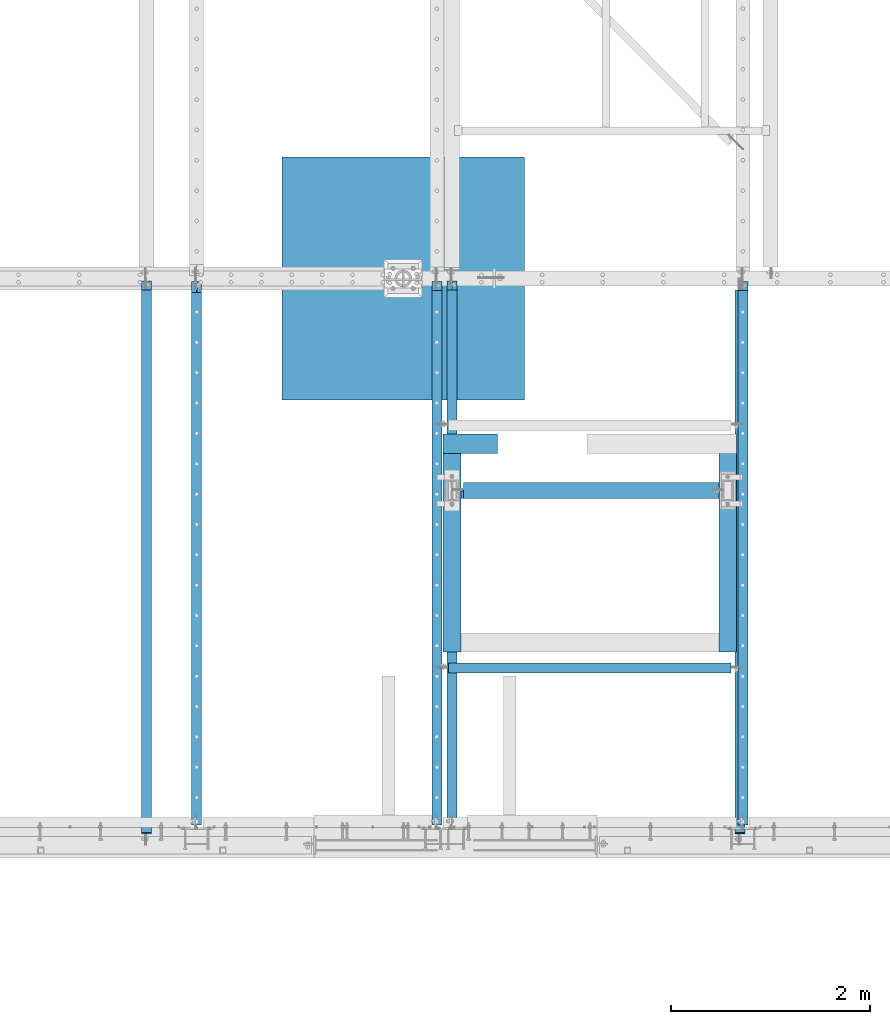
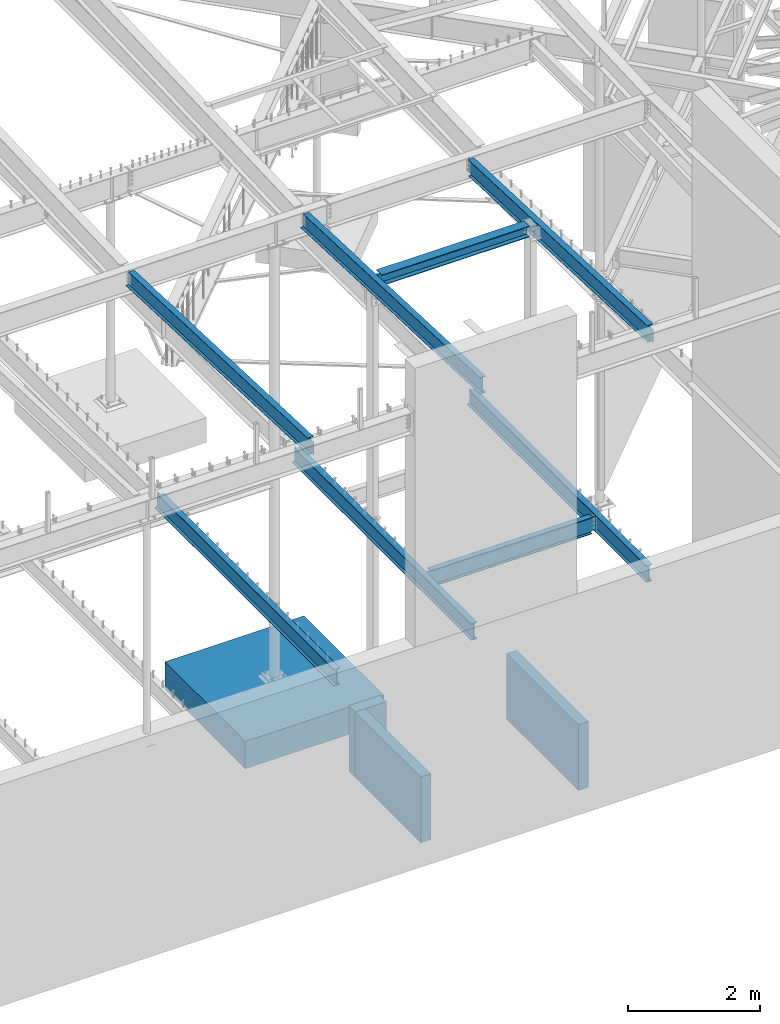
# One storey, part 315 of 975: 12 beams.
"""IFC2X3 building model written with IfcOpenShell, lengths in millimetres."""

from ifc_helpers import new_model, si_unit, frame, origin_with_axes, place, context, subcontext, project, spatial, faceted_brep, material, type_object, element, save


model = new_model("IFC2X3")

# Units and contexts
model_context = context("Model", 3, precision=1e-05, world=origin_with_axes())
body_context = subcontext(model_context, "Body", "Model", "MODEL_VIEW")
ifc_project = project(units=[si_unit("LENGTHUNIT", "METRE", prefix="MILLI"), si_unit("AREAUNIT", "SQUARE_METRE"), si_unit("VOLUMEUNIT", "CUBIC_METRE"), si_unit("MASSUNIT", "GRAM", prefix="KILO"), si_unit("TIMEUNIT", "SECOND"), si_unit("PLANEANGLEUNIT", "RADIAN"), si_unit("SOLIDANGLEUNIT", "STERADIAN"), si_unit("THERMODYNAMICTEMPERATUREUNIT", "DEGREE_CELSIUS"), si_unit("LUMINOUSINTENSITYUNIT", "LUMEN")], contexts=[model_context])

# Site, building, storey
site_placement = place(None, origin_with_axes())
site = spatial("IfcSite", under=ifc_project, at=site_placement, CompositionType="ELEMENT")
building_placement = place(site_placement, origin_with_axes())
building = spatial("IfcBuilding", under=site, at=building_placement, Name="Undefined", CompositionType="ELEMENT")
storey_placement = place(building_placement, origin_with_axes())
storey = spatial("IfcBuildingStorey", under=building, at=storey_placement, Name="Undefined", CompositionType="ELEMENT", Elevation=0.0)

# Beams
ifc_material_1 = material(Name="CONCRETE/5000")
beam_type_1 = type_object("IfcBeamType", PredefinedType="NOTDEFINED")
beam_1_placement = place(storey_placement, frame((23634.7000300942, 4160.83746255972, -609.6), z_axis=(0.0, 0.0, 1.0), x_axis=(1.0, 0.0, 0.0)))
element("IfcBeam", 1, at=beam_1_placement, inside=storey, type_object=beam_type_1, material=ifc_material_1, Name="WALL", context=body_context, shape_type="Brep", body=[
    faceted_brep([(0.0, 96.8375000000001, -609.6), (0.0, 96.8375000000001, 609.6), (546.100067562045, 96.8374999999996, 609.6), (546.100067562045, 96.8374999999996, -609.6), (0.0, -96.8375000000001, 609.6), (546.100067562045, -96.8375000000001, 609.6), (0.0, -96.8375000000001, -609.6), (546.100067562045, -96.8375000000001, -609.6)], [[[0, 1, 2, 3]], [[1, 4, 5, 2]], [[4, 6, 7, 5]], [[6, 0, 3, 7]], [[5, 7, 3, 2]], [[6, 4, 1, 0]]]),
])
beam_type_2 = type_object("IfcBeamType", PredefinedType="NOTDEFINED")
for number, where, z_axis, x_axis, name in (
    (2, (23723.6000300942, 2066.92513015896, -609.6), (0.0, 0.0, 1.0), (0.0, 1.0, 0.0), "WALL"),
    (3, (26492.2, 2066.92501138784, -609.6), (0.0, 0.0, 1.0), (0.0, 1.0, 0.0), "WALL"),
):
    element("IfcBeam", number, at=place(storey_placement, frame(where, z_axis=z_axis, x_axis=x_axis)), inside=storey, type_object=beam_type_2, material=ifc_material_1, Name=name, context=body_context, shape_type="Brep", body=[
        faceted_brep([(0.0, 88.9000000000015, -609.6), (0.0, 88.9000000000015, 609.6), (2190.74995117187, 88.9000000000015, 609.6), (2190.74995117187, 88.9000000000015, -609.6), (0.0, -88.9000000000015, 609.6), (2190.74995117187, -88.9000000000015, 609.6), (0.0, -88.9000000000015, -609.6), (2190.74995117187, -88.9000000000015, -609.6)], [[[0, 1, 2, 3]], [[1, 4, 5, 2]], [[4, 6, 7, 5]], [[6, 0, 3, 7]], [[5, 7, 3, 2]], [[6, 4, 1, 0]]]),
    ])
ifc_material_2 = material(Name="STEEL/A992")
beam_type_3 = type_object("IfcBeamType", Name="W12X14", PredefinedType="NOTDEFINED")
beam_2_placement = place(storey_placement, frame((26616.025, 95.5756617602171, 8307.50787178829), z_axis=(0.0, 0.039945880990807, 0.999201844770049), x_axis=(0.0, 0.999201844770049, -0.039945880990807)))
element("IfcBeam", 4, at=beam_2_placement, inside=storey, type_object=beam_type_3, material=ifc_material_2, Name="BEAM", ObjectType="W12X14", context=body_context, shape_type="Brep", body=[
    faceted_brep([(5608.57503248374, -2.38124999999854, -144.462500004352), (5608.57503248374, -50.7999999999993, -144.462500004352), (5608.57503248374, -50.7999999999993, -150.812500004353), (5608.57503248374, 50.7999999999993, -150.812500004353), (5608.57503248374, 50.7999999999993, -144.462500004352), (5608.57503248374, 2.38124999999854, -144.462500004352), (5608.57503248374, 2.38124999999854, -138.112499832895), (5608.57503248374, -2.38124999999854, -138.112499832895), (5609.54176240632, 2.38124999999854, -133.25242031485), (5609.54176240632, -2.38124999999854, -133.25242031485), (5612.2947763068, 2.38124999999854, -129.132243846697), (5612.2947763068, -2.38124999999854, -129.132243846697), (5616.41495277495, 2.38124999999854, -126.379229946219), (5616.41495277495, -2.38124999999854, -126.379229946219), (5621.27503229299, 2.38124999999854, -125.412500023635), (5621.27503229299, -2.38124999999854, -125.412500023635), (5709.15959663136, -2.38124999999854, -125.412500023731), (5709.15959663136, 2.38124999999854, -125.412500023731), (151.646194694746, 2.38124999999854, 144.462499999898), (151.646194694746, 50.7999999999993, 144.462499999898), (5608.57503248423, 50.7999999999993, 144.462499995674), (5608.57503248423, 2.38124999999854, 144.462499995674), (151.646194694766, -2.38124999999854, -131.762499810273), (151.646194694766, 2.38124999999854, -131.762499810273), (151.646194694768, 2.38124999999854, -144.46250000013), (151.646194694768, 50.7999999999993, -144.46250000013), (151.646194694769, 50.7999999999993, -150.812500000129), (151.646194694769, -50.7999999999993, -150.812500000129), (151.646194694768, -50.7999999999993, -144.46250000013), (151.646194694768, -2.38124999999854, -144.46250000013), (150.679464772175, -2.38124999999854, -126.902420292225), (150.679464772175, 2.38124999999854, -126.902420292225), (147.926450871693, -2.38124999999854, -122.782243824068), (147.926450871693, 2.38124999999854, -122.782243824068), (143.806274403537, -2.38124999999854, -120.029229923586), (143.806274403537, 2.38124999999854, -120.029229923586), (138.946194885491, -2.38124999999854, -119.062500000996), (138.946194885491, 2.38124999999854, -119.062500000996), (60.835200628926, -2.38124999999854, -119.062500000906), (60.835200628926, 2.38124999999854, -119.062500000907), (51.3154895105943, -2.38124999999854, 119.062499999025), (51.3154895105943, 2.38124999999854, 119.062499999025), (138.946194885527, -2.38124999999854, 119.062499999025), (138.946194885527, 2.38124999999854, 119.062499999025), (143.806274403572, -2.38124999999854, 120.029229921605), (143.806274403572, 2.38124999999854, 120.029229921605), (147.926450871724, -2.38124999999854, 122.782243822079), (147.926450871724, 2.38124999999854, 122.782243822079), (150.679464772199, -2.38124999999854, 126.902420290229), (150.679464772199, 2.38124999999854, 126.902420290229), (151.646194694783, -2.38124999999854, 131.762499808272), (151.646194694783, 2.38124999999854, 131.762499808272), (151.646194694751, -50.7999999999993, 150.812499999898), (151.646194694751, 50.7999999999993, 150.812499999898), (151.646194694746, -2.38124999999854, 144.462499999898), (151.646194694746, -50.7999999999993, 144.462499999898), (5608.57503248423, -2.38124999999854, 144.462499995674), (5608.57503248423, -50.7999999999993, 144.462499995674), (5608.57503248424, -50.7999999999993, 150.812499995674), (5608.57503248424, 50.7999999999993, 150.812499995674), (5608.57503248427, -2.38124999999854, 138.11249978577), (5608.57503248427, 2.38124999999854, 138.11249978577), (5609.54176240686, -2.38124999999854, 133.252420267723), (5609.54176240686, 2.38124999999854, 133.252420267723), (5612.29477630735, -2.38124999999854, 129.132243799562), (5612.29477630735, 2.38124999999854, 129.132243799562), (5616.4149527755, -2.38124999999854, 126.379229899077), (5616.4149527755, 2.38124999999854, 126.379229899077), (5621.27503229355, -2.38124999999854, 125.412499976481), (5621.27503229355, 2.38124999999854, 125.412499976481), (5699.13216758671, -2.38124999999854, 125.412499976492), (5699.13216758671, 2.38124999999854, 125.412499976492)], [[[0, 1, 2, 3, 4, 5, 6, 7]], [[7, 6, 8, 9]], [[9, 8, 10, 11]], [[11, 10, 12, 13]], [[13, 12, 14, 15]], [[16, 15, 14, 17]], [[18, 19, 20, 21]], [[22, 23, 24, 25, 26, 27, 28, 29]], [[30, 31, 23, 22]], [[32, 33, 31, 30]], [[34, 35, 33, 32]], [[36, 37, 35, 34]], [[38, 39, 37, 36]], [[40, 41, 39, 38]], [[42, 43, 41, 40]], [[44, 45, 43, 42]], [[46, 47, 45, 44]], [[48, 49, 47, 46]], [[50, 51, 49, 48]], [[52, 53, 19, 18, 51, 50, 54, 55]], [[55, 54, 56, 57]], [[52, 55, 57, 58]], [[53, 52, 58, 59]], [[19, 53, 59, 20]], [[58, 57, 56, 60, 61, 21, 20, 59]], [[62, 63, 61, 60]], [[64, 65, 63, 62]], [[66, 67, 65, 64]], [[68, 69, 67, 66]], [[70, 71, 69, 68]], [[71, 70, 16, 17]], [[12, 10, 8, 6, 5, 24, 23, 31, 33, 35, 37, 39, 41, 43, 45, 47, 49, 51, 18, 21, 61, 63, 65, 67, 69, 71, 17, 14]], [[25, 24, 5, 4]], [[26, 25, 4, 3]], [[27, 26, 3, 2]], [[28, 27, 2, 1]], [[29, 28, 1, 0]], [[70, 68, 66, 64, 62, 60, 56, 54, 50, 48, 46, 44, 42, 40, 38, 36, 34, 32, 30, 22, 29, 0, 7, 9, 11, 13, 15, 16]]]),
])
beam_3_placement = place(storey_placement, frame((23723.6, 298.748825629568, 8300.3691814021), z_axis=(0.0, 0.0401238250036801, 0.999194715091645), x_axis=(0.0, 0.999194715091645, -0.0401238250036801)))
element("IfcBeam", 5, at=beam_3_placement, inside=storey, type_object=beam_type_3, material=ifc_material_2, Name="BEAM", ObjectType="W12X14", context=body_context, shape_type="Brep", body=[
    faceted_brep([(37.277581501579, -2.38124999999854, -144.462500000039), (37.277581501579, -50.7999999999993, -144.462500000039), (5505.06195575205, -50.7999999999993, -144.462499998079), (5505.06195575205, -2.38124999999854, -144.462499998079), (37.5325731312614, -50.7999999999993, -150.812500000041), (5505.31694738173, -50.7999999999993, -150.812499998081), (37.5325731312614, 50.7999999999993, -150.812500000041), (5505.31694738173, 50.7999999999993, -150.812499998081), (37.277581501579, 50.7999999999993, -144.462500000039), (37.277581501579, 2.38124999999854, -144.462500000039), (5505.06195575205, 2.38124999999854, -144.462499998079), (5505.06195575205, 50.7999999999993, -144.462499998079), (5494.479803119, 2.38124999999854, 119.062500032711), (5494.479803119, -2.38124999999854, 119.062500032711), (25.6754623510329, -2.38124999999854, 144.462500000065), (25.6754623510329, -50.7999999999993, 144.462500000065), (25.4204707213506, -50.7999999999993, 150.812500000067), (25.4204707213506, 50.7999999999993, 150.812500000067), (25.6754623510329, 50.7999999999993, 144.462500000065), (25.6754623510329, 2.38124999999854, 144.462500000065), (5403.71694738037, 50.7999999999993, 144.462500001991), (5403.71694738037, 2.38124999999854, 144.462500001991), (5403.71694738036, 2.38124999999854, 131.762499841951), (5404.68367730295, 2.38124999999854, 126.902420323901), (5407.43669120343, 2.38124999999854, 122.782243855745), (5411.55686767158, 2.38124999999854, 120.029229955266), (5416.41694718963, 2.38124999999854, 119.06250003268), (5404.68367730295, -2.38124999999854, 126.902420323901), (5403.71694738036, -2.38124999999854, 131.762499841951), (5407.43669120343, -2.38124999999854, 122.782243855745), (5411.55686767158, -2.38124999999854, 120.029229955266), (5416.41694718963, -2.38124999999854, 119.06250003268), (5403.71694738037, -2.38124999999854, 144.462500001991), (5403.71694738037, -50.7999999999993, 144.462500001991), (5403.71694738037, -50.7999999999993, 150.812500001994), (5403.71694738037, 50.7999999999993, 150.812500001994)], [[[0, 1, 2, 3]], [[1, 4, 5, 2]], [[4, 6, 7, 5]], [[8, 9, 10, 11]], [[3, 2, 5, 7, 11, 10, 12, 13]], [[6, 8, 11, 7]], [[4, 1, 0, 14, 15, 16, 17, 18, 19, 9, 8, 6]], [[19, 18, 20, 21]], [[10, 9, 19, 21, 22, 23, 24, 25, 26, 12]], [[27, 23, 22, 28]], [[29, 24, 23, 27]], [[30, 25, 24, 29]], [[31, 26, 25, 30]], [[13, 12, 26, 31]], [[30, 29, 27, 28, 32, 14, 0, 3, 13, 31]], [[15, 14, 32, 33]], [[16, 15, 33, 34]], [[17, 16, 34, 35]], [[18, 17, 35, 20]], [[34, 33, 32, 28, 22, 21, 20, 35]]]),
])
beam_4_placement = place(storey_placement, frame((20653.375, 120.948825633107, 8307.50894703329), z_axis=(0.0, 0.0401238250036801, 0.999194715091645), x_axis=(0.0, 0.999194715091645, -0.0401238250036801)))
element("IfcBeam", 6, at=beam_4_placement, inside=storey, type_object=beam_type_3, material=ifc_material_2, Name="BEAM", ObjectType="W12X14", context=body_context, shape_type="Brep", body=[
    faceted_brep([(37.0520047015657, -2.38124999999854, -119.062500000143), (37.0520047015657, 2.38124999999854, -119.062500000143), (115.114860630816, 2.38124999999854, -119.062500000046), (115.114860630816, -2.38124999999854, -119.062500000046), (119.974940148861, 2.38124999999854, -120.029229922632), (119.974940148861, -2.38124999999854, -120.029229922632), (124.095116617013, 2.38124999999854, -122.78224382311), (124.095116617013, -2.38124999999854, -122.78224382311), (126.84813051749, 2.38124999999854, -126.902420291266), (126.84813051749, -2.38124999999854, -126.902420291266), (127.814860440076, -2.38124999999854, -131.762499809317), (127.814860440076, 2.38124999999854, -131.762499809317), (127.814860440082, 2.38124999999854, -144.462500000007), (127.814860440081, 50.7999999999993, -144.462500000007), (127.814860440083, 50.7999999999993, -150.812500000009), (127.814860440083, -50.7999999999993, -150.812500000009), (127.814860440082, -50.7999999999993, -144.462500000007), (127.814860440082, -2.38124999999854, -144.462500000007), (5581.66024242718, 50.7999999999993, 144.462500002061), (5581.66024242718, 2.38124999999854, 144.462500002061), (127.814860440073, 2.38124999999854, 144.4625000001), (127.814860440073, 50.7999999999993, 144.4625000001), (115.114860630788, -2.38124999999854, 119.062500000273), (115.114860630788, 2.38124999999854, 119.062500000273), (27.4898185884682, 2.38124999999854, 119.062500000271), (27.4898185884682, -2.38124999999854, 119.062500000271), (119.974940148833, -2.38124999999854, 120.029229922864), (119.974940148833, 2.38124999999854, 120.029229922864), (124.095116616988, -2.38124999999854, 122.782243823349), (124.095116616988, 2.38124999999854, 122.782243823349), (126.848130517467, -2.38124999999854, 126.902420291508), (126.848130517467, 2.38124999999854, 126.902420291508), (127.814860440057, -2.38124999999854, 131.76249980956), (127.814860440057, 2.38124999999854, 131.76249980956), (5581.66024242718, -50.7999999999993, 150.812500002065), (5581.66024242718, 50.7999999999993, 150.812500002065), (127.814860440071, 50.7999999999993, 150.812500000104), (127.814860440071, -50.7999999999993, 150.812499810841), (5581.66024242718, -50.7999999999993, 144.462500002061), (127.814860440073, -50.7999999999993, 144.4625000001), (5581.66024242718, -2.38124999999854, 144.462500002061), (127.814860440073, -2.38124999999854, 144.4625000001), (5581.66024242718, -2.38124999999854, 131.762499841927), (5581.66024242718, 2.38124999999854, 131.762499841927), (5582.62697234977, -2.38124999999854, 126.902420323875), (5582.62697234977, 2.38124999999854, 126.902420323875), (5585.37998625025, -2.38124999999854, 122.78224385572), (5585.37998625025, 2.38124999999854, 122.78224385572), (5589.5001627184, -2.38124999999854, 120.029229955242), (5589.5001627184, 2.38124999999854, 120.029229955242), (5594.36024223645, -2.38124999999854, 119.062500032656), (5594.36024223645, 2.38124999999854, 119.062500032656), (5672.42309816582, -2.38124999999854, 119.062500032685), (5672.42309816582, 2.38124999999854, 119.062500032685), (5683.00525079886, -2.38124999999854, -144.46249999801), (5683.00525079886, -50.7999999999993, -144.46249999801), (5683.26024242854, -50.7999999999993, -150.812499998011), (5683.26024242854, 50.7999999999993, -150.812499998011), (5683.00525079886, 50.7999999999993, -144.46249999801), (5683.00525079886, 2.38124999999854, -144.46249999801)], [[[0, 1, 2, 3]], [[3, 2, 4, 5]], [[5, 4, 6, 7]], [[7, 6, 8, 9]], [[10, 11, 12, 13, 14, 15, 16, 17]], [[9, 8, 11, 10]], [[18, 19, 20, 21]], [[22, 23, 24, 25]], [[26, 27, 23, 22]], [[28, 29, 27, 26]], [[30, 31, 29, 28]], [[32, 33, 31, 30]], [[34, 35, 36, 37]], [[38, 34, 37, 39]], [[40, 38, 39, 41]], [[37, 36, 21, 20, 33, 32, 41, 39]], [[35, 18, 21, 36]], [[34, 38, 40, 42, 43, 19, 18, 35]], [[44, 45, 43, 42]], [[46, 47, 45, 44]], [[48, 49, 47, 46]], [[50, 51, 49, 48]], [[52, 53, 51, 50]], [[54, 55, 56, 57, 58, 59, 53, 52]], [[55, 54, 17, 16]], [[56, 55, 16, 15]], [[57, 56, 15, 14]], [[58, 57, 14, 13]], [[59, 58, 13, 12]], [[6, 4, 2, 1, 24, 23, 27, 29, 31, 33, 20, 19, 43, 45, 47, 49, 51, 53, 59, 12, 11, 8]], [[25, 24, 1, 0]], [[54, 52, 50, 48, 46, 44, 42, 40, 41, 32, 30, 28, 26, 22, 25, 0, 3, 5, 7, 9, 10, 17]]]),
])
beam_type_4 = type_object("IfcBeamType", Name="W8X28", PredefinedType="NOTDEFINED")
beam_5_placement = place(storey_placement, frame((23723.5999908447, 3690.93747558594, 8213.48594882392), z_axis=(0.0, 0.0, 1.0), x_axis=(1.0, 0.0, 0.0)))
element("IfcBeam", 7, at=beam_5_placement, inside=storey, type_object=beam_type_4, material=ifc_material_2, Name="BEAM", ObjectType="W8X28", context=body_context, shape_type="Brep", body=[
    faceted_brep([(2705.10000915528, 3.96875, -90.4875000000002), (2705.10000915528, 82.5500000000002, -90.4875000000002), (116.681259155273, 82.5500000000002, -90.4875000000002), (116.681259155273, 3.94924991608423, -90.4875000000002), (27.781259155272, -3.96875, -90.4875000000002), (27.781259155272, -82.5500000000002, -90.4875000000002), (2705.10000915528, -82.5500000000002, -90.4875000000002), (2705.10000915528, -3.96875, -90.4875000000002), (27.781259155272, -82.5500000000002, -101.6), (2705.10000915528, -82.5500000000002, -101.6), (2705.10000915528, 3.96875, 90.4874999999993), (2705.10000915528, 82.5500000000002, 90.4874999999993), (2705.10000915528, 82.5500000000002, 101.6), (2705.10000915528, -82.5500000000002, 101.6), (2705.10000915528, -82.5500000000002, 90.4874999999993), (2705.10000915528, -3.96875, 90.4874999999993), (2705.10000915528, 82.5500000000002, -101.6), (116.681259155273, 82.5500000000002, -101.6), (116.681259155273, 3.94924991608423, -101.6), (27.781259155272, 3.94924991608423, -101.6), (27.781259155272, 3.96875, -90.4875000000002), (108.841338864055, -3.96875, 77.1667299271194), (108.841338864055, 3.96960344835315, 77.1667299271194), (103.981259346008, 3.96955142870183, 76.2000000045318), (103.981259346008, -3.96875, 76.2000000045318), (112.961515332208, -3.96875, 79.9197438275969), (112.961515332208, 3.96975191770798, 79.9197438275969), (115.714529232686, -3.96875, 84.0399202957506), (115.714529232686, 3.96997423365247, 84.0399202957506), (116.681259155273, -3.96875, 88.899999813797), (116.681259155273, 3.97023655059957, 88.899999813797), (27.781259155272, 3.96875, 76.2000000000317), (53.1812578201279, 3.96960526683824, 76.2000000000317), (116.681259155273, 3.96875, 90.4874999999993), (116.681259155273, 82.5500000000002, 90.4874999999993), (116.681259155273, 3.94924991608423, 94.4030120973985), (116.681259155273, 82.5500000000002, 94.4030120973985), (116.681259155273, 82.5500000000002, 101.6), (116.681259155273, -82.5500000000002, 101.6), (116.681259155273, -82.5500000000002, 90.4874999999993), (116.681259155273, -3.96875, 90.4874999999993), (53.1812578201279, -3.96875, 76.2000000000317), (27.781259155272, -3.96875, 76.2000000000317)], [[[0, 1, 2, 3]], [[4, 5, 6, 7]], [[5, 8, 9, 6]], [[0, 10, 11, 12, 13, 14, 15, 7, 6, 9, 16, 1]], [[1, 16, 17, 2]], [[2, 17, 18, 3]], [[16, 9, 8, 19, 18, 17]], [[3, 18, 19, 20]], [[21, 22, 23, 24]], [[25, 26, 22, 21]], [[27, 28, 26, 25]], [[29, 30, 28, 27]], [[10, 0, 3, 20, 31, 32, 23, 22, 26, 28, 30, 33]], [[11, 10, 33, 34]], [[34, 33, 35, 36]], [[12, 11, 34, 36, 37]], [[13, 12, 37, 38]], [[14, 13, 38, 39]], [[15, 14, 39, 40]], [[38, 37, 36, 35, 33, 30, 29, 40, 39]], [[27, 25, 21, 24, 41, 42, 4, 7, 15, 40, 29]], [[20, 19, 8, 5, 4, 42, 31]], [[41, 32, 31, 42]], [[24, 23, 32, 41]]]),
])
beam_type_5 = type_object("IfcBeamType", Name="W12X19", PredefinedType="NOTDEFINED")
beam_6_placement = place(storey_placement, frame((23571.2, 1907.86465672034, 3783.0125), z_axis=(0.0, 0.0, 1.0), x_axis=(1.0, 0.0, 0.0)))
element("IfcBeam", 8, at=beam_6_placement, inside=storey, type_object=beam_type_5, material=ifc_material_2, Name="BEAM", ObjectType="W12X19", context=body_context, shape_type="Brep", body=[
    faceted_brep([(2955.925, -3.17499999999995, -144.4625), (2955.925, -50.8, -144.4625), (2955.925, -50.8, -153.98749999433), (2955.925, 50.8, -153.9875), (2955.925, 50.8, -146.462500046992), (2955.925, 3.47549991607684, -146.462500046992), (2955.925, 3.47549991607684, -144.4625), (2955.925, 3.17499999999995, -144.4625), (2955.925, 3.17499999999995, -141.287499809265), (2955.925, -3.17499999999995, -141.287499809265), (2956.89172992258, 3.17499999999995, -136.42742029122), (2956.89172992258, -3.17499999999995, -136.42742029122), (2959.64474382306, 3.17499999999995, -132.307243823066), (2959.64474382306, -3.17499999999995, -132.307243823066), (2963.76492029121, 3.17499999999995, -129.554229922588), (2963.76492029121, -3.17499999999995, -129.554229922588), (2968.62499980926, 3.17499999999995, -128.5875), (2968.62499980926, -3.17499999999995, -128.5875), (3044.825, -3.17499999999995, -128.5875), (3044.825, 3.17499999999995, -128.5875), (2949.575, 3.47549991607684, -144.4625), (2949.575, 3.47549991607684, -146.462500046992), (2949.575, 50.8, -146.462500046992), (2949.575, 50.8, -144.4625), (117.475000000002, 3.17499999999995, 144.4625), (117.475000000002, 50.8, 144.4625), (123.825000000001, 50.8, 144.4625), (2949.575, 50.8, 144.4625), (2955.925, 50.8, 144.4625), (2955.925, 3.17499999999995, 144.4625), (123.825000000001, 3.77549991607657, -144.4625), (123.825000000001, 3.77549991607657, -146.462500567734), (117.475000000002, 3.77549991607657, -146.462500567734), (117.475000000002, 3.77549991607657, -144.4625), (123.825000000001, 50.8, -144.4625), (123.825000000001, 50.8, -146.462500567734), (117.475000000002, 50.8, -146.462500567734), (117.475000000002, -3.17499999999995, -141.287499809264), (117.475000000002, 3.17499999999995, -141.287499809264), (117.475000000002, 3.17499999999995, -144.4625), (117.475000000002, 50.8, -153.9875), (117.475000000002, -50.8, -153.987499813315), (117.475000000002, -50.8, -144.4625), (117.475000000002, -3.17499999999995, -144.4625), (116.508270077415, -3.17499999999995, -136.427420291219), (116.508270077415, 3.17499999999995, -136.427420291219), (113.755256176937, -3.17499999999995, -132.307243823065), (113.755256176937, 3.17499999999995, -132.307243823065), (109.635079708783, -3.17499999999995, -129.554229922587), (109.635079708783, 3.17499999999995, -129.554229922587), (104.775000190737, -3.17499999999995, -128.587499999999), (104.775000190737, 3.17499999999995, -128.587499999999), (28.5750000000007, -3.17499999999995, -128.587499999999), (28.5750000000007, 3.17499999999995, -128.587499999999), (28.5750000000007, -3.17499999999995, 128.587500000001), (28.5750000000007, 3.17499999999995, 128.587500000001), (104.775000190737, -3.17499999999995, 128.587500000001), (104.775000190737, 3.17499999999995, 128.587500000001), (109.635079708783, -3.17499999999995, 129.554229922589), (109.635079708783, 3.17499999999995, 129.554229922589), (113.755256176937, -3.17499999999995, 132.307243823067), (113.755256176937, 3.17499999999995, 132.307243823067), (116.508270077415, -3.17499999999995, 136.427420291221), (116.508270077415, 3.17499999999995, 136.427420291221), (117.475000000002, -3.17499999999995, 141.287499809266), (117.475000000002, 3.17499999999995, 141.287499809266), (117.475000000002, -50.8, 153.987499813315), (117.475000000002, 50.8, 153.9875), (117.475000000002, -3.17499999999995, 144.4625), (117.475000000002, -50.8, 144.4625), (2955.925, -3.17499999999995, 144.4625), (2955.925, -50.8, 144.4625), (2955.925, -50.8, 153.98749999433), (2955.925, 50.8, 153.9875), (2955.925, -3.17499999999995, 141.287499809265), (2955.925, 3.17499999999995, 141.287499809265), (2956.89172992258, -3.17499999999995, 136.42742029122), (2956.89172992258, 3.17499999999995, 136.42742029122), (2959.64474382306, -3.17499999999995, 132.307243823066), (2959.64474382306, 3.17499999999995, 132.307243823066), (2963.76492029121, -3.17499999999995, 129.554229922588), (2963.76492029121, 3.17499999999995, 129.554229922588), (2968.62499980926, -3.17499999999995, 128.5875), (2968.62499980926, 3.17499999999995, 128.5875), (3044.825, -3.17499999999995, 128.5875), (3044.825, 3.17499999999995, 128.5875)], [[[0, 1, 2, 3, 4, 5, 6, 7, 8, 9]], [[9, 8, 10, 11]], [[11, 10, 12, 13]], [[13, 12, 14, 15]], [[15, 14, 16, 17]], [[18, 17, 16, 19]], [[20, 21, 22, 23]], [[24, 25, 26, 27, 28, 29]], [[30, 31, 32, 33]], [[34, 35, 31, 30]], [[31, 35, 36, 32]], [[37, 38, 39, 33, 32, 36, 40, 41, 42, 43]], [[44, 45, 38, 37]], [[46, 47, 45, 44]], [[48, 49, 47, 46]], [[50, 51, 49, 48]], [[52, 53, 51, 50]], [[54, 55, 53, 52]], [[56, 57, 55, 54]], [[58, 59, 57, 56]], [[60, 61, 59, 58]], [[62, 63, 61, 60]], [[64, 65, 63, 62]], [[66, 67, 25, 24, 65, 64, 68, 69]], [[69, 68, 70, 71]], [[66, 69, 71, 72]], [[67, 66, 72, 73]], [[27, 26, 25, 67, 73, 28]], [[72, 71, 70, 74, 75, 29, 28, 73]], [[76, 77, 75, 74]], [[78, 79, 77, 76]], [[80, 81, 79, 78]], [[82, 83, 81, 80]], [[84, 85, 83, 82]], [[85, 84, 18, 19]], [[14, 12, 10, 8, 7, 39, 38, 45, 47, 49, 51, 53, 55, 57, 59, 61, 63, 65, 24, 29, 75, 77, 79, 81, 83, 85, 19, 16]], [[20, 23, 34, 30, 33, 39, 7, 6]], [[21, 20, 6, 5]], [[22, 21, 5, 4]], [[40, 36, 35, 34, 23, 22, 4, 3]], [[41, 40, 3, 2]], [[42, 41, 2, 1]], [[43, 42, 1, 0]], [[84, 82, 80, 78, 76, 74, 70, 68, 64, 62, 60, 58, 56, 54, 52, 50, 48, 46, 44, 37, 43, 0, 9, 11, 13, 15, 17, 18]]]),
])
beam_7_placement = place(storey_placement, frame((26644.6, 114.300000000004, 3783.0125), z_axis=(0.0, 0.0, 1.0), x_axis=(0.0, 1.0, 0.0)))
element("IfcBeam", 9, at=beam_7_placement, inside=storey, type_object=beam_type_5, material=ifc_material_2, Name="BEAM", ObjectType="W12X19", context=body_context, shape_type="Brep", body=[
    faceted_brep([(215.899999999996, -3.17499999999927, -144.4625), (215.899999999996, -50.7999999999993, -144.4625), (5676.10624999999, -50.7999999999993, -144.4625), (5676.10624999999, -3.17499999999927, -144.4625), (215.899999999996, -50.7999999999993, -153.9875), (5676.10624999999, -50.7999999999993, -153.9875), (215.899999999996, 50.7999999999993, -153.9875), (5676.10624999999, 50.7999999999993, -153.9875), (215.899999999996, 50.7999999999993, -144.4625), (215.899999999996, 3.17499999999927, -144.4625), (5676.10624999999, 3.17499999999927, -144.4625), (5676.10624999999, 50.7999999999993, -144.4625), (5676.10624999999, 3.17499999999927, 128.587500000001), (5676.10624999999, -3.17499999999927, 128.587500000001), (215.899999999996, -3.17499999999927, 144.4625), (215.899999999996, -50.7999999999993, 144.4625), (215.899999999996, -50.7999999999993, 153.9875), (215.899999999996, 50.7999999999993, 153.9875), (215.899999999996, 50.7999999999993, 144.4625), (215.899999999996, 3.17499999999927, 144.4625), (5587.20624999999, 50.7999999999993, 144.4625), (5587.20624999999, 3.17499999999927, 144.4625), (5587.20624999999, 3.17499999999927, 141.287499809266), (5588.17297992258, 3.17499999999927, 136.427420291221), (5590.92599382306, 3.17499999999927, 132.307243823067), (5595.04617029121, 3.17499999999927, 129.554229922589), (5599.90624980926, 3.17499999999927, 128.587500000001), (5588.17297992258, -3.17499999999927, 136.427420291221), (5587.20624999999, -3.17499999999927, 141.287499809266), (5590.92599382306, -3.17499999999927, 132.307243823067), (5595.04617029121, -3.17499999999927, 129.554229922589), (5599.90624980926, -3.17499999999927, 128.587500000001), (5587.20624999999, -3.17499999999927, 144.4625), (5587.20624999999, -50.7999999999993, 144.4625), (5587.20624999999, -50.7999999999993, 153.9875), (5587.20624999999, 50.7999999999993, 153.9875)], [[[0, 1, 2, 3]], [[1, 4, 5, 2]], [[4, 6, 7, 5]], [[8, 9, 10, 11]], [[3, 2, 5, 7, 11, 10, 12, 13]], [[6, 8, 11, 7]], [[4, 1, 0, 14, 15, 16, 17, 18, 19, 9, 8, 6]], [[19, 18, 20, 21]], [[10, 9, 19, 21, 22, 23, 24, 25, 26, 12]], [[27, 23, 22, 28]], [[29, 24, 23, 27]], [[30, 25, 24, 29]], [[31, 26, 25, 30]], [[13, 12, 26, 31]], [[30, 29, 27, 28, 32, 14, 0, 3, 13, 31]], [[15, 14, 32, 33]], [[16, 15, 33, 34]], [[17, 16, 34, 35]], [[18, 17, 35, 20]], [[34, 33, 32, 28, 22, 21, 20, 35]]]),
])
beam_8_placement = place(storey_placement, frame((23571.2, 114.300000000004, 3783.0125), z_axis=(0.0, 0.0, 1.0), x_axis=(0.0, 1.0, 0.0)))
element("IfcBeam", 10, at=beam_8_placement, inside=storey, type_object=beam_type_5, material=ifc_material_2, Name="BEAM", ObjectType="W12X19", context=body_context, shape_type="Brep", body=[
    faceted_brep([(215.899999999996, -3.17499999999927, -144.4625), (215.899999999996, -50.7999999999993, -144.4625), (5676.10624999999, -50.7999999999993, -144.4625), (5676.10624999999, -3.17499999999927, -144.4625), (215.899999999996, -50.7999999999993, -153.9875), (5676.10624999999, -50.7999999999993, -153.9875), (215.899999999996, 50.7999999999993, -153.9875), (5676.10624999999, 50.7999999999993, -153.9875), (215.899999999996, 50.7999999999993, -144.4625), (215.899999999996, 3.17499999999927, -144.4625), (5676.10624999999, 3.17499999999927, -144.4625), (5676.10624999999, 50.7999999999993, -144.4625), (5676.10624999999, 3.17499999999927, 128.587500000001), (5676.10624999999, -3.17499999999927, 128.587500000001), (215.899999999996, -3.17499999999927, 144.4625), (215.899999999996, -50.7999999999993, 144.4625), (215.899999999996, -50.7999999999993, 153.9875), (215.899999999996, 50.7999999999993, 153.9875), (215.899999999996, 50.7999999999993, 144.4625), (215.899999999996, 3.17499999999927, 144.4625), (5587.20624999999, 50.7999999999993, 144.4625), (5587.20624999999, 3.17499999999927, 144.4625), (5587.20624999999, 3.17499999999927, 141.287499809266), (5588.17297992258, 3.17499999999927, 136.427420291221), (5590.92599382306, 3.17499999999927, 132.307243823067), (5595.04617029121, 3.17499999999927, 129.554229922589), (5599.90624980926, 3.17499999999927, 128.587500000001), (5588.17297992258, -3.17499999999927, 136.427420291221), (5587.20624999999, -3.17499999999927, 141.287499809266), (5590.92599382306, -3.17499999999927, 132.307243823067), (5595.04617029121, -3.17499999999927, 129.554229922589), (5599.90624980926, -3.17499999999927, 128.587500000001), (5587.20624999999, -3.17499999999927, 144.4625), (5587.20624999999, -50.7999999999993, 144.4625), (5587.20624999999, -50.7999999999993, 153.9875), (5587.20624999999, 50.7999999999993, 153.9875)], [[[0, 1, 2, 3]], [[1, 4, 5, 2]], [[4, 6, 7, 5]], [[8, 9, 10, 11]], [[3, 2, 5, 7, 11, 10, 12, 13]], [[6, 8, 11, 7]], [[4, 1, 0, 14, 15, 16, 17, 18, 19, 9, 8, 6]], [[19, 18, 20, 21]], [[10, 9, 19, 21, 22, 23, 24, 25, 26, 12]], [[27, 23, 22, 28]], [[29, 24, 23, 27]], [[30, 25, 24, 29]], [[31, 26, 25, 30]], [[13, 12, 26, 31]], [[30, 29, 27, 28, 32, 14, 0, 3, 13, 31]], [[15, 14, 32, 33]], [[16, 15, 33, 34]], [[17, 16, 34, 35]], [[18, 17, 35, 20]], [[34, 33, 32, 28, 22, 21, 20, 35]]]),
])
beam_9_placement = place(storey_placement, frame((21158.2, 114.300000000004, 3783.0125), z_axis=(0.0, 0.0, 1.0), x_axis=(0.0, 1.0, 0.0)))
element("IfcBeam", 11, at=beam_9_placement, inside=storey, type_object=beam_type_5, material=ifc_material_2, Name="BEAM", ObjectType="W12X19", context=body_context, shape_type="Brep", body=[
    faceted_brep([(215.899999999996, -3.17499999999927, -144.4625), (215.899999999996, -50.7999999999993, -144.4625), (5674.51874999999, -50.7999999999993, -144.4625), (5674.51874999999, -3.17499999999927, -144.4625), (215.899999999996, -50.7999999999993, -153.9875), (5674.51874999999, -50.7999999999993, -153.9875), (215.899999999996, 50.7999999999993, -153.9875), (5674.51874999999, 50.7999999999993, -153.9875), (215.899999999996, 50.7999999999993, -144.4625), (215.899999999996, 3.17499999999927, -144.4625), (5674.51874999999, 3.17499999999927, -144.4625), (5674.51874999999, 50.7999999999993, -144.4625), (5674.51874999999, 3.17499999999927, 128.5875), (5674.51874999999, -3.17499999999927, 128.5875), (215.899999999996, -3.17499999999927, 144.4625), (215.899999999996, -50.7999999999993, 144.4625), (215.899999999996, -50.7999999999993, 153.9875), (215.899999999996, 50.7999999999993, 153.9875), (215.899999999996, 50.7999999999993, 144.4625), (215.899999999996, 3.17499999999927, 144.4625), (5566.56874999999, 50.7999999999993, 144.4625), (5566.56874999999, 3.17499999999927, 144.4625), (5566.56874999999, 3.17499999999927, 141.287499809265), (5567.53547992258, 3.17499999999927, 136.42742029122), (5570.28849382306, 3.17499999999927, 132.307243823066), (5574.40867029121, 3.17499999999927, 129.554229922588), (5579.26874980926, 3.17499999999927, 128.5875), (5567.53547992258, -3.17499999999927, 136.42742029122), (5566.56874999999, -3.17499999999927, 141.287499809265), (5570.28849382306, -3.17499999999927, 132.307243823066), (5574.40867029121, -3.17499999999927, 129.554229922588), (5579.26874980926, -3.17499999999927, 128.5875), (5566.56874999999, -3.17499999999927, 144.4625), (5566.56874999999, -50.7999999999993, 144.4625), (5566.56874999999, -50.7999999999993, 153.9875), (5566.56874999999, 50.7999999999993, 153.9875)], [[[0, 1, 2, 3]], [[1, 4, 5, 2]], [[4, 6, 7, 5]], [[8, 9, 10, 11]], [[3, 2, 5, 7, 11, 10, 12, 13]], [[6, 8, 11, 7]], [[4, 1, 0, 14, 15, 16, 17, 18, 19, 9, 8, 6]], [[19, 18, 20, 21]], [[10, 9, 19, 21, 22, 23, 24, 25, 26, 12]], [[27, 23, 22, 28]], [[29, 24, 23, 27]], [[30, 25, 24, 29]], [[31, 26, 25, 30]], [[13, 12, 26, 31]], [[30, 29, 27, 28, 32, 14, 0, 3, 13, 31]], [[15, 14, 32, 33]], [[16, 15, 33, 34]], [[17, 16, 34, 35]], [[18, 17, 35, 20]], [[34, 33, 32, 28, 22, 21, 20, 35]]]),
])
beam_type_6 = type_object("IfcBeamType", PredefinedType="NOTDEFINED")
beam_10_placement = place(storey_placement, frame((22013.8625, 5819.775023622, -558.799999999999), z_axis=(0.0, 0.0, 1.0), x_axis=(1.0, 0.0, 0.0)))
element("IfcBeam", 12, at=beam_10_placement, inside=storey, type_object=beam_type_6, material=ifc_material_1, Name="FOOTING", context=body_context, shape_type="Brep", body=[
    faceted_brep([(0.0, 1219.2, -254.0), (0.0, 1219.2, 254.0), (2438.4, 1219.2, 254.0), (2438.4, 1219.2, -254.0), (0.0, -1219.2, 254.0), (2438.4, -1219.2, 254.0), (0.0, -1219.2, -254.0), (2438.4, -1219.2, -254.0)], [[[0, 1, 2, 3]], [[1, 4, 5, 2]], [[4, 6, 7, 5]], [[6, 0, 3, 7]], [[5, 7, 3, 2]], [[6, 4, 1, 0]]]),
])

save(model, "model.ifc")
